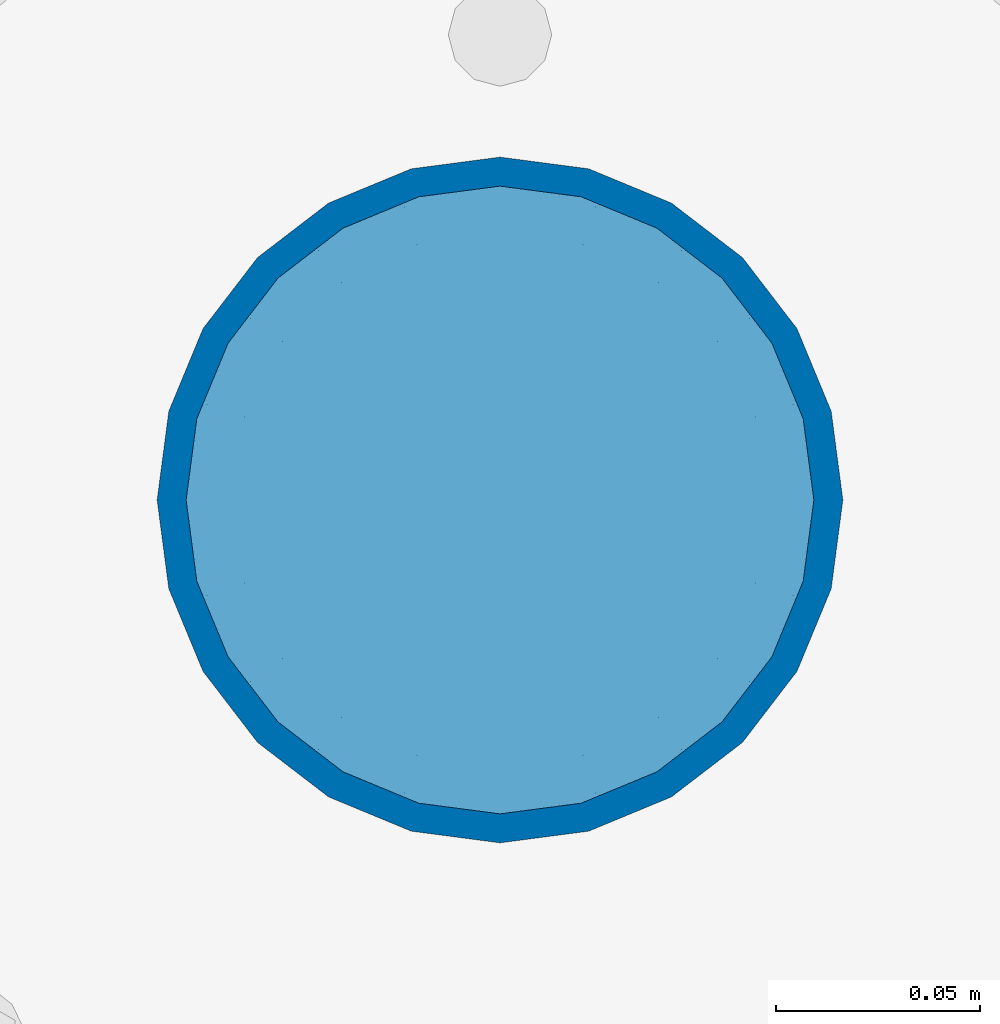
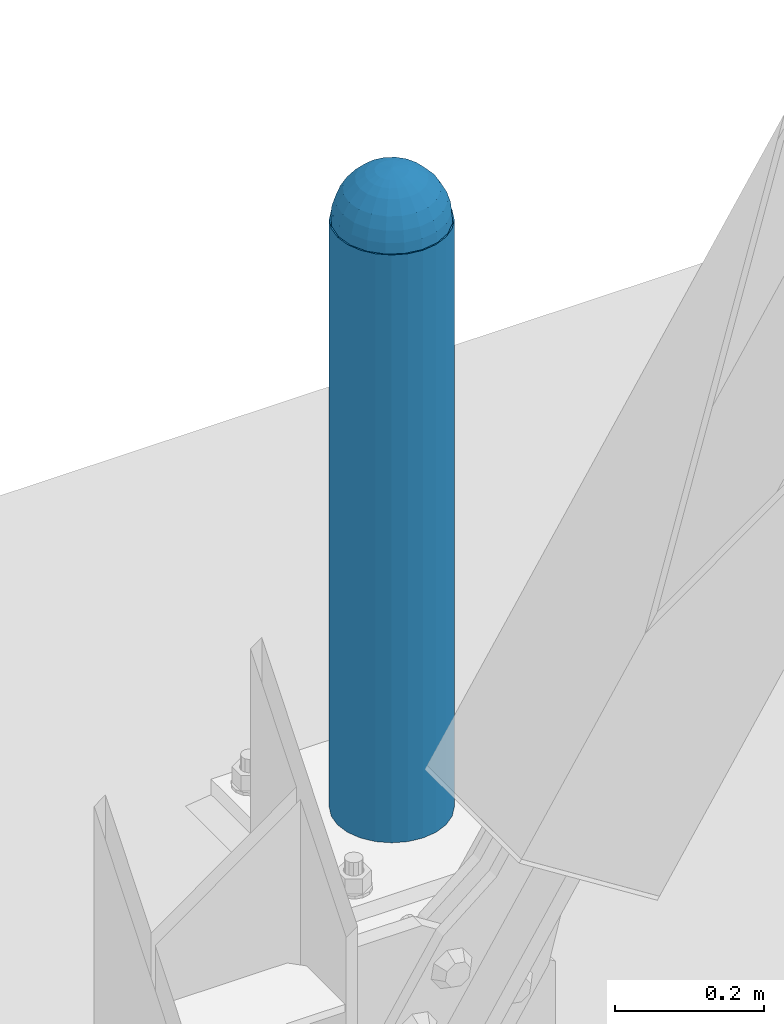
# One storey, part 1563 of 3843: 2 columns, 2 elements without a shape of their own.
"""IFC2X3 building model written with IfcOpenShell, lengths in millimetres."""

from ifc_helpers import new_model, si_unit, frame, origin_with_axes, place, context, subcontext, project, spatial, faceted_brep, material, type_object, element, aggregate, save


model = new_model("IFC2X3")

# Units and contexts
model_context = context("Model", 3, precision=1e-05, world=origin_with_axes())
body_context = subcontext(model_context, "Body", "Model", "MODEL_VIEW")
ifc_project = project(units=[si_unit("LENGTHUNIT", "METRE", prefix="MILLI"), si_unit("AREAUNIT", "SQUARE_METRE"), si_unit("VOLUMEUNIT", "CUBIC_METRE"), si_unit("MASSUNIT", "GRAM", prefix="KILO"), si_unit("TIMEUNIT", "SECOND"), si_unit("PLANEANGLEUNIT", "RADIAN"), si_unit("SOLIDANGLEUNIT", "STERADIAN"), si_unit("THERMODYNAMICTEMPERATUREUNIT", "DEGREE_CELSIUS"), si_unit("LUMINOUSINTENSITYUNIT", "LUMEN")], contexts=[model_context])

# Site, building, storey
site_placement = place(None, origin_with_axes())
site = spatial("IfcSite", under=ifc_project, at=site_placement, CompositionType="ELEMENT")
building_placement = place(site_placement, origin_with_axes())
building = spatial("IfcBuilding", under=site, at=building_placement, Name="Undefined", CompositionType="ELEMENT")
storey_placement = place(building_placement, origin_with_axes())
storey = spatial("IfcBuildingStorey", under=building, at=storey_placement, Name="Undefined", CompositionType="ELEMENT", Elevation=0.0)

# Assembly, column
assembly_1_placement = place(storey_placement, origin_with_axes())
assembly_1 = element("IfcElementAssembly", 1, at=assembly_1_placement, inside=storey, Name="CONC. FILL", AssemblyPlace="NOTDEFINED", PredefinedType="REINFORCEMENT_UNIT")
ifc_material_1 = material(Name="CONCRETE/1500")
column_type_1 = type_object("IfcColumnType", PredefinedType="NOTDEFINED")
column_1_placement = place(assembly_1_placement, frame((23469.6, 89725.5, 31411.8625), z_axis=(-1.0, 0.0, 0.0), x_axis=(0.0, 0.0, 1.0)))
column_1 = element("IfcColumn", 2, at=column_1_placement, type_object=column_type_1, material=ifc_material_1, Name="CONC. FILL", context=body_context, shape_type="Brep", body=[
    faceted_brep([(0.0, 0.0, 2.0), (0.0, -0.619999999995343, 1.89999999999964), (3.36549999999988, -7.1422259999963, 21.9814139999999), (3.36549999999988, 0.0, 23.1139999999996), (0.0, -1.17999999999302, 1.6200000000008), (3.36549999999988, -13.5910319999966, 18.6992260000006), (0.0, -1.61999999999534, 1.18000000000029), (3.36549999999988, -18.699225999997, 13.5910320000003), (0.0, -1.89999999999418, 0.6200000000008), (3.36549999999988, -21.9814139999944, 7.14222599999994), (0.0, -2.0, 0.0), (3.36549999999988, -23.1140000000014, 0.0), (0.0, -1.89999999999418, -0.6200000000008), (3.36549999999988, -21.9814139999944, -7.14222599999994), (0.0, -1.61999999999534, -1.18000000000029), (3.36549999999988, -18.699225999997, -13.5910320000003), (0.0, -1.17999999999302, -1.6200000000008), (3.36549999999988, -13.5910319999966, -18.6992260000006), (0.0, -0.619999999995343, -1.89999999999964), (3.36549999999988, -7.1422259999963, -21.9814139999999), (0.0, 0.0, -2.0), (3.36549999999988, 0.0, -23.1139999999996), (0.0, 0.619999999995343, -1.89999999999964), (3.36549999999988, 7.1422259999963, -21.9814139999999), (0.0, 1.17999999999302, -1.6200000000008), (3.36549999999988, 13.5910319999966, -18.6992260000006), (0.0, 1.61999999999534, -1.18000000000029), (3.36549999999988, 18.699225999997, -13.5910320000003), (0.0, 1.89999999999418, -0.6200000000008), (3.36549999999988, 21.9814139999944, -7.14222599999994), (0.0, 2.0, 0.0), (3.36549999999988, 23.1140000000014, 0.0), (0.0, 1.89999999999418, 0.6200000000008), (3.36549999999988, 21.9814139999944, 7.14222599999994), (0.0, 1.61999999999534, 1.18000000000029), (3.36549999999988, 18.699225999997, 13.5910320000003), (0.0, 1.17999999999302, 1.6200000000008), (3.36549999999988, 13.5910319999966, 18.6992260000006), (0.0, 0.619999999995343, 1.89999999999964), (3.36549999999988, 7.1422259999963, 21.9814139999999), (8.41374999999971, -11.1214661999984, 34.2282018000005), (8.41374999999971, 0.0, 35.9917999999998), (8.41374999999971, -21.1631784000056, 29.1173662000001), (8.41374999999971, -29.1173661999928, 21.1631784000001), (8.41374999999971, -34.2282017999969, 11.1214662000002), (8.41374999999971, -35.9918000000034, 0.0), (8.41374999999971, -34.2282017999969, -11.1214662000002), (8.41374999999971, -29.1173661999928, -21.1631784000001), (8.41374999999971, -21.1631784000056, -29.1173662000001), (8.41374999999971, -11.1214661999984, -34.2282018000005), (8.41374999999971, 0.0, -35.9917999999998), (8.41374999999971, 11.1214661999984, -34.2282018000005), (8.41374999999971, 21.1631784000056, -29.1173662000001), (8.41374999999971, 29.1173661999928, -21.1631784000001), (8.41374999999971, 34.2282017999969, -11.1214662000002), (8.41374999999971, 35.9918000000034, 0.0), (8.41374999999971, 34.2282017999969, 11.1214662000002), (8.41374999999971, 29.1173661999928, 21.1631784000001), (8.41374999999971, 21.1631784000056, 29.1173662000001), (8.41374999999971, 11.1214661999984, 34.2282018000005), (16.8274999999994, -15.3047700000025, 47.1030300000002), (16.8274999999994, 0.0, 49.5300000000007), (16.8274999999994, -29.1236400000053, 40.0697700000001), (16.8274999999994, -40.0697700000019, 29.1236399999998), (16.8274999999994, -47.1030299999984, 15.3047700000006), (16.8274999999994, -49.5299999999988, 0.0), (16.8274999999994, -47.1030299999984, -15.3047700000006), (16.8274999999994, -40.0697700000019, -29.1236399999998), (16.8274999999994, -29.1236400000053, -40.0697700000001), (16.8274999999994, -15.3047700000025, -47.1030300000002), (16.8274999999994, 0.0, -49.5300000000007), (16.8274999999994, 15.3047700000025, -47.1030300000002), (16.8274999999994, 29.1236400000053, -40.0697700000001), (16.8274999999994, 40.0697700000019, -29.1236399999998), (16.8274999999994, 47.1030299999984, -15.3047700000006), (16.8274999999994, 49.5299999999988, 0.0), (16.8274999999994, 47.1030299999984, 15.3047700000006), (16.8274999999994, 40.0697700000019, 29.1236399999998), (16.8274999999994, 29.1236400000053, 40.0697700000001), (16.8274999999994, 15.3047700000025, 47.1030300000002), (33.6549999999988, -20.4063599999936, 62.8040400000009), (33.6549999999988, 0.0, 66.0400000000009), (33.6549999999988, -38.831520000007, 53.4263599999995), (33.6549999999988, -53.4263599999977, 38.8315199999997), (33.6549999999988, -62.8040400000027, 20.4063600000009), (33.6549999999988, -66.0399999999936, 0.0), (33.6549999999988, -62.8040400000027, -20.4063600000009), (33.6549999999988, -53.4263599999977, -38.8315199999997), (33.6549999999988, -38.831520000007, -53.4263599999995), (33.6549999999988, -20.4063599999936, -62.8040400000009), (33.6549999999988, 0.0, -66.0400000000009), (33.6549999999988, 20.4063599999936, -62.8040400000009), (33.6549999999988, 38.831520000007, -53.4263599999995), (33.6549999999988, 53.4263599999977, -38.8315199999997), (33.6549999999988, 62.8040400000027, -20.4063600000009), (33.6549999999988, 66.0399999999936, 0.0), (33.6549999999988, 62.8040400000027, 20.4063600000009), (33.6549999999988, 53.4263599999977, 38.8315199999997), (33.6549999999988, 38.831520000007, 53.4263599999995), (33.6549999999988, 20.4063599999936, 62.8040400000009), (50.4824999999983, -23.3907901500061, 71.9891308499991), (50.4824999999983, 0.0, 75.6983500000006), (50.4824999999983, -44.5106298000028, 61.23996515), (50.4824999999983, -61.2399651500018, 44.5106297999992), (50.4824999999983, -71.9891308499937, 23.3907901500006), (50.4824999999983, -75.698350000006, 0.0), (50.4824999999983, -71.9891308499937, -23.3907901500006), (50.4824999999983, -61.2399651500018, -44.5106297999992), (50.4824999999983, -44.5106298000028, -61.23996515), (50.4824999999983, -23.3907901500061, -71.9891308499991), (50.4824999999983, 0.0, -75.6983500000006), (50.4824999999983, 23.3907901500061, -71.9891308499991), (50.4824999999983, 44.5106298000028, -61.23996515), (50.4824999999983, 61.2399651500018, -44.5106297999992), (50.4824999999983, 71.9891308499937, -23.3907901500006), (50.4824999999983, 75.698350000006, 0.0), (50.4824999999983, 71.9891308499937, 23.3907901500006), (50.4824999999983, 61.2399651500018, 44.5106297999992), (50.4824999999983, 44.5106298000028, 61.23996515), (50.4824999999983, 23.3907901500061, 71.9891308499991), (67.3099999999977, -24.9977910000016, 76.9349490000004), (67.3099999999977, 0.0, 80.8989999999994), (67.3099999999977, -47.5686120000028, 65.4472910000004), (67.3099999999977, -65.447291000004, 47.5686119999991), (67.3099999999977, -76.9349490000022, 24.9977909999998), (67.3099999999977, -80.8990000000049, 0.0), (67.3099999999977, -76.9349490000022, -24.9977909999998), (67.3099999999977, -65.447291000004, -47.5686119999991), (67.3099999999977, -47.5686120000028, -65.4472910000004), (67.3099999999977, -24.9977910000016, -76.9349490000004), (67.3099999999977, 0.0, -80.8989999999994), (67.3099999999977, 24.9977910000016, -76.9349490000004), (67.3099999999977, 47.5686120000028, -65.4472910000004), (67.3099999999977, 65.447291000004, -47.5686119999991), (67.3099999999977, 76.9349490000022, -24.9977909999998), (67.3099999999977, 80.8990000000049, 0.0), (67.3099999999977, 76.9349490000022, 24.9977909999998), (67.3099999999977, 65.447291000004, 47.5686119999991), (67.3099999999977, 47.5686120000028, 65.4472910000004), (67.3099999999977, 24.9977910000016, 76.9349490000004), (84.1374999999935, -25.5079499999993, 78.5050499999998), (84.1374999999935, 0.0, 82.5499999999993), (84.1374999999935, -48.5393999999942, 66.7829500000007), (84.1374999999935, -66.7829499999934, 48.5393999999997), (84.1374999999935, -78.505050000007, 25.5079499999993), (84.1374999999935, -82.5500000000029, 0.0), (84.1374999999935, -78.505050000007, -25.5079499999993), (84.1374999999935, -66.7829499999934, -48.5393999999997), (84.1374999999935, -48.5393999999942, -66.7829500000007), (84.1374999999935, -25.5079499999993, -78.5050499999998), (84.1374999999935, 0.0, -82.5499999999993), (84.1374999999935, 25.5079499999993, -78.5050499999998), (84.1374999999935, 48.5393999999942, -66.7829500000007), (84.1374999999935, 66.7829499999934, -48.5393999999997), (84.1374999999935, 78.505050000007, -25.5079499999993), (84.1374999999935, 82.5500000000029, 0.0), (84.1374999999935, 78.505050000007, 25.5079499999993), (84.1374999999935, 66.7829499999934, 48.5393999999997), (84.1374999999935, 48.5393999999942, 66.7829500000007), (84.1374999999935, 25.5079499999993, 78.5050499999998), (100.964999999993, -24.9977910000016, 76.9349490000004), (100.964999999993, 0.0, 80.8989999999994), (100.964999999993, -47.5686120000028, 65.4472910000004), (100.964999999993, -65.447291000004, 47.5686119999991), (100.964999999993, -76.9349490000022, 24.9977909999998), (100.964999999993, -80.8990000000049, 0.0), (100.964999999993, -76.9349490000022, -24.9977909999998), (100.964999999993, -65.447291000004, -47.5686119999991), (100.964999999993, -47.5686120000028, -65.4472910000004), (100.964999999993, -24.9977910000016, -76.9349490000004), (100.964999999993, 0.0, -80.8989999999994), (100.964999999993, 24.9977910000016, -76.9349490000004), (100.964999999993, 47.5686120000028, -65.4472910000004), (100.964999999993, 65.447291000004, -47.5686119999991), (100.964999999993, 76.9349490000022, -24.9977909999998), (100.964999999993, 80.8990000000049, 0.0), (100.964999999993, 76.9349490000022, 24.9977909999998), (100.964999999993, 65.447291000004, 47.5686119999991), (100.964999999993, 47.5686120000028, 65.4472910000004), (100.964999999993, 24.9977910000016, 76.9349490000004), (117.792499999992, -23.3907901500061, 71.9891308499991), (117.792499999992, 0.0, 75.6983500000006), (117.792499999992, -44.5106298000028, 61.23996515), (117.792499999992, -61.2399651500018, 44.5106297999992), (117.792499999992, -71.9891308499937, 23.3907901500006), (117.792499999992, -75.698350000006, 0.0), (117.792499999992, -71.9891308499937, -23.3907901500006), (117.792499999992, -61.2399651500018, -44.5106297999992), (117.792499999992, -44.5106298000028, -61.23996515), (117.792499999992, -23.3907901500061, -71.9891308499991), (117.792499999992, 0.0, -75.6983500000006), (117.792499999992, 23.3907901500061, -71.9891308499991), (117.792499999992, 44.5106298000028, -61.23996515), (117.792499999992, 61.2399651500018, -44.5106297999992), (117.792499999992, 71.9891308499937, -23.3907901500006), (117.792499999992, 75.698350000006, 0.0), (117.792499999992, 71.9891308499937, 23.3907901500006), (117.792499999992, 61.2399651500018, 44.5106297999992), (117.792499999992, 44.5106298000028, 61.23996515), (117.792499999992, 23.3907901500061, 71.9891308499991), (134.619999999992, -20.4063599999936, 62.8040400000009), (134.619999999992, 0.0, 66.0400000000009), (134.619999999992, -38.831520000007, 53.4263599999995), (134.619999999992, -53.4263599999977, 38.8315199999997), (134.619999999992, -62.8040400000027, 20.4063600000009), (134.619999999992, -66.0399999999936, 0.0), (134.619999999992, -62.8040400000027, -20.4063600000009), (134.619999999992, -53.4263599999977, -38.8315199999997), (134.619999999992, -38.831520000007, -53.4263599999995), (134.619999999992, -20.4063599999936, -62.8040400000009), (134.619999999992, 0.0, -66.0400000000009), (134.619999999992, 20.4063599999936, -62.8040400000009), (134.619999999992, 38.831520000007, -53.4263599999995), (134.619999999992, 53.4263599999977, -38.8315199999997), (134.619999999992, 62.8040400000027, -20.4063600000009), (134.619999999992, 66.0399999999936, 0.0), (134.619999999992, 62.8040400000027, 20.4063600000009), (134.619999999992, 53.4263599999977, 38.8315199999997), (134.619999999992, 38.831520000007, 53.4263599999995), (134.619999999992, 20.4063599999936, 62.8040400000009), (151.447499999991, -15.3047700000025, 47.1030300000002), (151.447499999991, 0.0, 49.5300000000007), (151.447499999991, -29.1236400000053, 40.0697700000001), (151.447499999991, -40.0697700000019, 29.1236399999998), (151.447499999991, -47.1030299999984, 15.3047700000006), (151.447499999991, -49.5299999999988, 0.0), (151.447499999991, -47.1030299999984, -15.3047700000006), (151.447499999991, -40.0697700000019, -29.1236399999998), (151.447499999991, -29.1236400000053, -40.0697700000001), (151.447499999991, -15.3047700000025, -47.1030300000002), (151.447499999991, 0.0, -49.5300000000007), (151.447499999991, 15.3047700000025, -47.1030300000002), (151.447499999991, 29.1236400000053, -40.0697700000001), (151.447499999991, 40.0697700000019, -29.1236399999998), (151.447499999991, 47.1030299999984, -15.3047700000006), (151.447499999991, 49.5299999999988, 0.0), (151.447499999991, 47.1030299999984, 15.3047700000006), (151.447499999991, 40.0697700000019, 29.1236399999998), (151.447499999991, 29.1236400000053, 40.0697700000001), (151.447499999991, 15.3047700000025, 47.1030300000002), (159.861249999991, -11.1214661999984, 34.2282018000005), (159.861249999991, 0.0, 35.9917999999998), (159.861249999991, -21.1631784000056, 29.1173662000001), (159.861249999991, -29.1173661999928, 21.1631784000001), (159.861249999991, -34.2282017999969, 11.1214662000002), (159.861249999991, -35.9918000000034, 0.0), (159.861249999991, -34.2282017999969, -11.1214662000002), (159.861249999991, -29.1173661999928, -21.1631784000001), (159.861249999991, -21.1631784000056, -29.1173662000001), (159.861249999991, -11.1214661999984, -34.2282018000005), (159.861249999991, 0.0, -35.9917999999998), (159.861249999991, 11.1214661999984, -34.2282018000005), (159.861249999991, 21.1631784000056, -29.1173662000001), (159.861249999991, 29.1173661999928, -21.1631784000001), (159.861249999991, 34.2282017999969, -11.1214662000002), (159.861249999991, 35.9918000000034, 0.0), (159.861249999991, 34.2282017999969, 11.1214662000002), (159.861249999991, 29.1173661999928, 21.1631784000001), (159.861249999991, 21.1631784000056, 29.1173662000001), (159.861249999991, 11.1214661999984, 34.2282018000005), (164.909499999991, -7.1422259999963, 21.9814139999999), (164.909499999991, 0.0, 23.1139999999996), (164.909499999991, -13.5910319999966, 18.6992260000006), (164.909499999991, -18.699225999997, 13.5910320000003), (164.909499999991, -21.9814139999944, 7.14222599999994), (164.909499999991, -23.1140000000014, 0.0), (164.909499999991, -21.9814139999944, -7.14222599999994), (164.909499999991, -18.699225999997, -13.5910320000003), (164.909499999991, -13.5910319999966, -18.6992260000006), (164.909499999991, -7.1422259999963, -21.9814139999999), (164.909499999991, 0.0, -23.1139999999996), (164.909499999991, 7.1422259999963, -21.9814139999999), (164.909499999991, 13.5910319999966, -18.6992260000006), (164.909499999991, 18.699225999997, -13.5910320000003), (164.909499999991, 21.9814139999944, -7.14222599999994), (164.909499999991, 23.1140000000014, 0.0), (164.909499999991, 21.9814139999944, 7.14222599999994), (164.909499999991, 18.699225999997, 13.5910320000003), (164.909499999991, 13.5910319999966, 18.6992260000006), (164.909499999991, 7.1422259999963, 21.9814139999999), (168.274999999991, -0.619999999995343, 1.89999999999964), (168.274999999991, 0.0, 2.0), (168.274999999991, -1.17999999999302, 1.6200000000008), (168.274999999991, -1.61999999999534, 1.18000000000029), (168.274999999991, -1.89999999999418, 0.6200000000008), (168.274999999991, -2.0, 0.0), (168.274999999991, -1.89999999999418, -0.6200000000008), (168.274999999991, -1.61999999999534, -1.18000000000029), (168.274999999991, -1.17999999999302, -1.6200000000008), (168.274999999991, -0.619999999995343, -1.89999999999964), (168.274999999991, 0.0, -2.0), (168.274999999991, 0.619999999995343, -1.89999999999964), (168.274999999991, 1.17999999999302, -1.6200000000008), (168.274999999991, 1.61999999999534, -1.18000000000029), (168.274999999991, 1.89999999999418, -0.6200000000008), (168.274999999991, 2.0, 0.0), (168.274999999991, 1.89999999999418, 0.6200000000008), (168.274999999991, 1.61999999999534, 1.18000000000029), (168.274999999991, 1.17999999999302, 1.6200000000008), (168.274999999991, 0.619999999995343, 1.89999999999964)], [[[0, 1, 2, 3]], [[1, 4, 5, 2]], [[4, 6, 7, 5]], [[6, 8, 9, 7]], [[8, 10, 11, 9]], [[10, 12, 13, 11]], [[12, 14, 15, 13]], [[14, 16, 17, 15]], [[16, 18, 19, 17]], [[18, 20, 21, 19]], [[20, 22, 23, 21]], [[22, 24, 25, 23]], [[24, 26, 27, 25]], [[26, 28, 29, 27]], [[28, 30, 31, 29]], [[30, 32, 33, 31]], [[32, 34, 35, 33]], [[34, 36, 37, 35]], [[36, 38, 39, 37]], [[38, 0, 3, 39]], [[38, 36, 34, 32, 30, 28, 26, 24, 22, 20, 18, 16, 14, 12, 10, 8, 6, 4, 1, 0]], [[3, 2, 40, 41]], [[2, 5, 42, 40]], [[5, 7, 43, 42]], [[7, 9, 44, 43]], [[9, 11, 45, 44]], [[11, 13, 46, 45]], [[13, 15, 47, 46]], [[15, 17, 48, 47]], [[17, 19, 49, 48]], [[19, 21, 50, 49]], [[21, 23, 51, 50]], [[23, 25, 52, 51]], [[25, 27, 53, 52]], [[27, 29, 54, 53]], [[29, 31, 55, 54]], [[31, 33, 56, 55]], [[33, 35, 57, 56]], [[35, 37, 58, 57]], [[37, 39, 59, 58]], [[39, 3, 41, 59]], [[41, 40, 60, 61]], [[40, 42, 62, 60]], [[42, 43, 63, 62]], [[43, 44, 64, 63]], [[44, 45, 65, 64]], [[45, 46, 66, 65]], [[46, 47, 67, 66]], [[47, 48, 68, 67]], [[48, 49, 69, 68]], [[49, 50, 70, 69]], [[50, 51, 71, 70]], [[51, 52, 72, 71]], [[52, 53, 73, 72]], [[53, 54, 74, 73]], [[54, 55, 75, 74]], [[55, 56, 76, 75]], [[56, 57, 77, 76]], [[57, 58, 78, 77]], [[58, 59, 79, 78]], [[59, 41, 61, 79]], [[61, 60, 80, 81]], [[60, 62, 82, 80]], [[62, 63, 83, 82]], [[63, 64, 84, 83]], [[64, 65, 85, 84]], [[65, 66, 86, 85]], [[66, 67, 87, 86]], [[67, 68, 88, 87]], [[68, 69, 89, 88]], [[69, 70, 90, 89]], [[70, 71, 91, 90]], [[71, 72, 92, 91]], [[72, 73, 93, 92]], [[73, 74, 94, 93]], [[74, 75, 95, 94]], [[75, 76, 96, 95]], [[76, 77, 97, 96]], [[77, 78, 98, 97]], [[78, 79, 99, 98]], [[79, 61, 81, 99]], [[81, 80, 100, 101]], [[80, 82, 102, 100]], [[82, 83, 103, 102]], [[83, 84, 104, 103]], [[84, 85, 105, 104]], [[85, 86, 106, 105]], [[86, 87, 107, 106]], [[87, 88, 108, 107]], [[88, 89, 109, 108]], [[89, 90, 110, 109]], [[90, 91, 111, 110]], [[91, 92, 112, 111]], [[92, 93, 113, 112]], [[93, 94, 114, 113]], [[94, 95, 115, 114]], [[95, 96, 116, 115]], [[96, 97, 117, 116]], [[97, 98, 118, 117]], [[98, 99, 119, 118]], [[99, 81, 101, 119]], [[101, 100, 120, 121]], [[100, 102, 122, 120]], [[102, 103, 123, 122]], [[103, 104, 124, 123]], [[104, 105, 125, 124]], [[105, 106, 126, 125]], [[106, 107, 127, 126]], [[107, 108, 128, 127]], [[108, 109, 129, 128]], [[109, 110, 130, 129]], [[110, 111, 131, 130]], [[111, 112, 132, 131]], [[112, 113, 133, 132]], [[113, 114, 134, 133]], [[114, 115, 135, 134]], [[115, 116, 136, 135]], [[116, 117, 137, 136]], [[117, 118, 138, 137]], [[118, 119, 139, 138]], [[119, 101, 121, 139]], [[121, 120, 140, 141]], [[120, 122, 142, 140]], [[122, 123, 143, 142]], [[123, 124, 144, 143]], [[124, 125, 145, 144]], [[125, 126, 146, 145]], [[126, 127, 147, 146]], [[127, 128, 148, 147]], [[128, 129, 149, 148]], [[129, 130, 150, 149]], [[130, 131, 151, 150]], [[131, 132, 152, 151]], [[132, 133, 153, 152]], [[133, 134, 154, 153]], [[134, 135, 155, 154]], [[135, 136, 156, 155]], [[136, 137, 157, 156]], [[137, 138, 158, 157]], [[138, 139, 159, 158]], [[139, 121, 141, 159]], [[141, 140, 160, 161]], [[140, 142, 162, 160]], [[142, 143, 163, 162]], [[143, 144, 164, 163]], [[144, 145, 165, 164]], [[145, 146, 166, 165]], [[146, 147, 167, 166]], [[147, 148, 168, 167]], [[148, 149, 169, 168]], [[149, 150, 170, 169]], [[150, 151, 171, 170]], [[151, 152, 172, 171]], [[152, 153, 173, 172]], [[153, 154, 174, 173]], [[154, 155, 175, 174]], [[155, 156, 176, 175]], [[156, 157, 177, 176]], [[157, 158, 178, 177]], [[158, 159, 179, 178]], [[159, 141, 161, 179]], [[161, 160, 180, 181]], [[160, 162, 182, 180]], [[162, 163, 183, 182]], [[163, 164, 184, 183]], [[164, 165, 185, 184]], [[165, 166, 186, 185]], [[166, 167, 187, 186]], [[167, 168, 188, 187]], [[168, 169, 189, 188]], [[169, 170, 190, 189]], [[170, 171, 191, 190]], [[171, 172, 192, 191]], [[172, 173, 193, 192]], [[173, 174, 194, 193]], [[174, 175, 195, 194]], [[175, 176, 196, 195]], [[176, 177, 197, 196]], [[177, 178, 198, 197]], [[178, 179, 199, 198]], [[179, 161, 181, 199]], [[181, 180, 200, 201]], [[180, 182, 202, 200]], [[182, 183, 203, 202]], [[183, 184, 204, 203]], [[184, 185, 205, 204]], [[185, 186, 206, 205]], [[186, 187, 207, 206]], [[187, 188, 208, 207]], [[188, 189, 209, 208]], [[189, 190, 210, 209]], [[190, 191, 211, 210]], [[191, 192, 212, 211]], [[192, 193, 213, 212]], [[193, 194, 214, 213]], [[194, 195, 215, 214]], [[195, 196, 216, 215]], [[196, 197, 217, 216]], [[197, 198, 218, 217]], [[198, 199, 219, 218]], [[199, 181, 201, 219]], [[201, 200, 220, 221]], [[200, 202, 222, 220]], [[202, 203, 223, 222]], [[203, 204, 224, 223]], [[204, 205, 225, 224]], [[205, 206, 226, 225]], [[206, 207, 227, 226]], [[207, 208, 228, 227]], [[208, 209, 229, 228]], [[209, 210, 230, 229]], [[210, 211, 231, 230]], [[211, 212, 232, 231]], [[212, 213, 233, 232]], [[213, 214, 234, 233]], [[214, 215, 235, 234]], [[215, 216, 236, 235]], [[216, 217, 237, 236]], [[217, 218, 238, 237]], [[218, 219, 239, 238]], [[219, 201, 221, 239]], [[221, 220, 240, 241]], [[220, 222, 242, 240]], [[222, 223, 243, 242]], [[223, 224, 244, 243]], [[224, 225, 245, 244]], [[225, 226, 246, 245]], [[226, 227, 247, 246]], [[227, 228, 248, 247]], [[228, 229, 249, 248]], [[229, 230, 250, 249]], [[230, 231, 251, 250]], [[231, 232, 252, 251]], [[232, 233, 253, 252]], [[233, 234, 254, 253]], [[234, 235, 255, 254]], [[235, 236, 256, 255]], [[236, 237, 257, 256]], [[237, 238, 258, 257]], [[238, 239, 259, 258]], [[239, 221, 241, 259]], [[241, 240, 260, 261]], [[240, 242, 262, 260]], [[242, 243, 263, 262]], [[243, 244, 264, 263]], [[244, 245, 265, 264]], [[245, 246, 266, 265]], [[246, 247, 267, 266]], [[247, 248, 268, 267]], [[248, 249, 269, 268]], [[249, 250, 270, 269]], [[250, 251, 271, 270]], [[251, 252, 272, 271]], [[252, 253, 273, 272]], [[253, 254, 274, 273]], [[254, 255, 275, 274]], [[255, 256, 276, 275]], [[256, 257, 277, 276]], [[257, 258, 278, 277]], [[258, 259, 279, 278]], [[259, 241, 261, 279]], [[261, 260, 280, 281]], [[260, 262, 282, 280]], [[262, 263, 283, 282]], [[263, 264, 284, 283]], [[264, 265, 285, 284]], [[265, 266, 286, 285]], [[266, 267, 287, 286]], [[267, 268, 288, 287]], [[268, 269, 289, 288]], [[269, 270, 290, 289]], [[270, 271, 291, 290]], [[271, 272, 292, 291]], [[272, 273, 293, 292]], [[273, 274, 294, 293]], [[274, 275, 295, 294]], [[275, 276, 296, 295]], [[276, 277, 297, 296]], [[277, 278, 298, 297]], [[278, 279, 299, 298]], [[279, 261, 281, 299]], [[282, 283, 284, 285, 286, 287, 288, 289, 290, 291, 292, 293, 294, 295, 296, 297, 298, 299, 281, 280]]]),
])
aggregate(assembly_1, [column_1])

assembly_2_placement = place(storey_placement, origin_with_axes())
assembly_2 = element("IfcElementAssembly", 3, at=assembly_2_placement, inside=storey, Name="PIPE_BOLLARD", AssemblyPlace="NOTDEFINED", PredefinedType="RIGID_FRAME")
ifc_material_2 = material()
column_type_2 = type_object("IfcColumnType", Name="PIPE6SCH40", PredefinedType="NOTDEFINED")
column_2_placement = place(assembly_2_placement, frame((23469.6, 89725.5, 30480.0), z_axis=(-1.0, 0.0, 0.0), x_axis=(0.0, 0.0, 1.0)))
column_2 = element("IfcColumn", 4, at=column_2_placement, type_object=column_type_2, material=ifc_material_2, Name="PIPE_BOLLARD", ObjectType="PIPE6SCH40", context=body_context, shape_type="Brep", body=[
    faceted_brep([(50.7999999999993, -77.0890000000072, 0.0), (50.7999999999993, -74.4622560228017, 19.9521013679114), (1016.0, -74.4622560228017, 19.9521013679114), (1016.0, -77.0890000000072, 0.0), (50.7999999999993, -66.7610323523404, 38.5445000000036), (1016.0, -66.7610323523404, 38.5445000000036), (50.7999999999993, -54.5101546548831, 54.5101546548904), (1016.0, -54.5101546548831, 54.5101546548904), (50.7999999999993, -38.5445000000036, 66.7610323523404), (1016.0, -38.5445000000036, 66.7610323523404), (50.7999999999993, -19.9521013679041, 74.4622560227945), (1016.0, -19.9521013679041, 74.4622560227945), (50.7999999999993, 0.0, 77.0889999999999), (1016.0, 0.0, 77.0889999999999), (50.7999999999993, 19.9521013679041, 74.4622560227945), (1016.0, 19.9521013679041, 74.4622560227945), (50.7999999999993, 38.5445000000036, 66.7610323523404), (1016.0, 38.5445000000036, 66.7610323523404), (50.7999999999993, 54.5101546548831, 54.5101546548904), (1016.0, 54.5101546548831, 54.5101546548904), (50.7999999999993, 66.7610323523404, 38.5445000000036), (1016.0, 66.7610323523404, 38.5445000000036), (50.7999999999993, 74.4622560228017, 19.9521013679114), (1016.0, 74.4622560228017, 19.9521013679114), (50.7999999999993, 77.0890000000072, 0.0), (1016.0, 77.0890000000072, 0.0), (50.7999999999993, 74.4622560228017, -19.9521013679114), (1016.0, 74.4622560228017, -19.9521013679114), (50.7999999999993, 66.7610323523404, -38.5445000000036), (1016.0, 66.7610323523404, -38.5445000000036), (50.7999999999993, 54.5101546548831, -54.5101546548904), (1016.0, 54.5101546548831, -54.5101546548904), (50.7999999999993, 38.5445000000036, -66.7610323523404), (1016.0, 38.5445000000036, -66.7610323523404), (50.7999999999993, 19.9521013679041, -74.4622560227945), (1016.0, 19.9521013679041, -74.4622560227945), (50.7999999999993, 0.0, -77.0889999999999), (1016.0, 0.0, -77.0889999999999), (50.7999999999993, -19.9521013679041, -74.4622560227945), (1016.0, -19.9521013679041, -74.4622560227945), (50.7999999999993, -38.5445000000036, -66.7610323523404), (1016.0, -38.5445000000036, -66.7610323523404), (50.7999999999993, -54.5101546548831, -54.5101546548904), (1016.0, -54.5101546548831, -54.5101546548904), (50.7999999999993, -66.7610323523404, -38.5445000000036), (1016.0, -66.7610323523404, -38.5445000000036), (50.7999999999993, -74.4622560228017, -19.9521013679114), (1016.0, -74.4622560228017, -19.9521013679114), (50.7999999999993, -84.2010000000009, 0.0), (50.7999999999993, -81.3319204993604, -21.7928224166753), (1016.0, -81.3319204993604, -21.7928224166753), (1016.0, -84.2010000000009, 0.0), (50.7999999999993, -72.9202050240565, -42.1005000000005), (1016.0, -72.9202050240565, -42.1005000000005), (50.7999999999993, -59.5390980826924, -59.5390980826851), (1016.0, -59.5390980826924, -59.5390980826851), (50.7999999999993, -42.1005000000005, -72.9202050240565), (1016.0, -42.1005000000005, -72.9202050240565), (50.7999999999993, -21.7928224166826, -81.3319204993677), (1016.0, -21.7928224166826, -81.3319204993677), (50.7999999999993, 0.0, -84.2010000000009), (1016.0, 0.0, -84.2010000000009), (50.7999999999993, 21.7928224166826, -81.3319204993677), (1016.0, 21.7928224166826, -81.3319204993677), (50.7999999999993, 42.1005000000005, -72.9202050240565), (1016.0, 42.1005000000005, -72.9202050240565), (50.7999999999993, 59.5390980826924, -59.5390980826851), (1016.0, 59.5390980826924, -59.5390980826851), (50.7999999999993, 72.9202050240565, -42.1005000000005), (1016.0, 72.9202050240565, -42.1005000000005), (50.7999999999993, 81.3319204993604, -21.7928224166753), (1016.0, 81.3319204993604, -21.7928224166753), (50.7999999999993, 84.2010000000009, 0.0), (1016.0, 84.2010000000009, 0.0), (50.7999999999993, 81.3319204993604, 21.7928224166753), (1016.0, 81.3319204993604, 21.7928224166753), (50.7999999999993, 72.9202050240565, 42.1005000000005), (1016.0, 72.9202050240565, 42.1005000000005), (50.7999999999993, 59.5390980826924, 59.5390980826851), (1016.0, 59.5390980826924, 59.5390980826851), (50.7999999999993, 42.1005000000005, 72.9202050240565), (1016.0, 42.1005000000005, 72.9202050240565), (50.7999999999993, 21.7928224166826, 81.3319204993677), (1016.0, 21.7928224166826, 81.3319204993677), (50.7999999999993, 0.0, 84.2010000000009), (1016.0, 0.0, 84.2010000000009), (50.7999999999993, -21.7928224166826, 81.3319204993677), (1016.0, -21.7928224166826, 81.3319204993677), (50.7999999999993, -42.1005000000005, 72.9202050240565), (1016.0, -42.1005000000005, 72.9202050240565), (50.7999999999993, -59.5390980826924, 59.5390980826851), (1016.0, -59.5390980826924, 59.5390980826851), (50.7999999999993, -72.9202050240565, 42.1005000000005), (1016.0, -72.9202050240565, 42.1005000000005), (50.7999999999993, -81.3319204993604, 21.7928224166753), (1016.0, -81.3319204993604, 21.7928224166753)], [[[0, 1, 2, 3]], [[1, 4, 5, 2]], [[4, 6, 7, 5]], [[6, 8, 9, 7]], [[8, 10, 11, 9]], [[10, 12, 13, 11]], [[12, 14, 15, 13]], [[14, 16, 17, 15]], [[16, 18, 19, 17]], [[18, 20, 21, 19]], [[20, 22, 23, 21]], [[22, 24, 25, 23]], [[24, 26, 27, 25]], [[26, 28, 29, 27]], [[28, 30, 31, 29]], [[30, 32, 33, 31]], [[32, 34, 35, 33]], [[34, 36, 37, 35]], [[36, 38, 39, 37]], [[38, 40, 41, 39]], [[40, 42, 43, 41]], [[42, 44, 45, 43]], [[44, 46, 47, 45]], [[46, 0, 3, 47]], [[48, 49, 50, 51]], [[49, 52, 53, 50]], [[52, 54, 55, 53]], [[54, 56, 57, 55]], [[56, 58, 59, 57]], [[58, 60, 61, 59]], [[60, 62, 63, 61]], [[62, 64, 65, 63]], [[64, 66, 67, 65]], [[66, 68, 69, 67]], [[68, 70, 71, 69]], [[70, 72, 73, 71]], [[72, 74, 75, 73]], [[74, 76, 77, 75]], [[76, 78, 79, 77]], [[78, 80, 81, 79]], [[80, 82, 83, 81]], [[82, 84, 85, 83]], [[84, 86, 87, 85]], [[86, 88, 89, 87]], [[88, 90, 91, 89]], [[90, 92, 93, 91]], [[92, 94, 95, 93]], [[94, 48, 51, 95]], [[53, 55, 57, 59, 61, 63, 65, 67, 69, 71, 73, 75, 77, 79, 81, 83, 85, 87, 89, 91, 93, 95, 51, 50], [5, 7, 9, 11, 13, 15, 17, 19, 21, 23, 25, 27, 29, 31, 33, 35, 37, 39, 41, 43, 45, 47, 3, 2]], [[94, 92, 90, 88, 86, 84, 82, 80, 78, 76, 74, 72, 70, 68, 66, 64, 62, 60, 58, 56, 54, 52, 49, 48], [46, 44, 42, 40, 38, 36, 34, 32, 30, 28, 26, 24, 22, 20, 18, 16, 14, 12, 10, 8, 6, 4, 1, 0]]]),
])
aggregate(assembly_2, [column_2])

save(model, "model.ifc")
